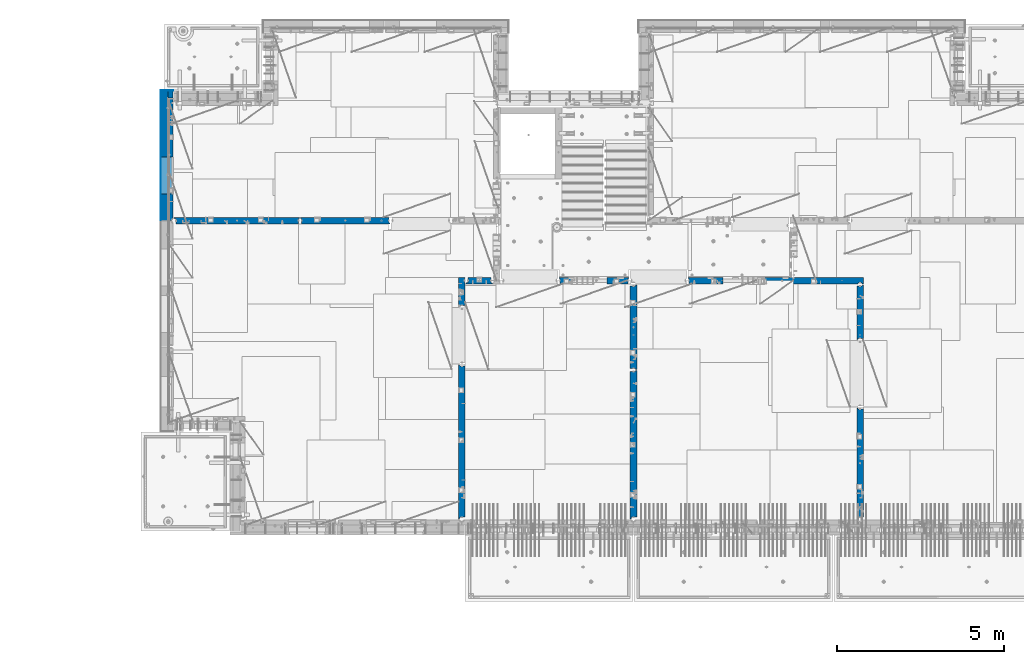
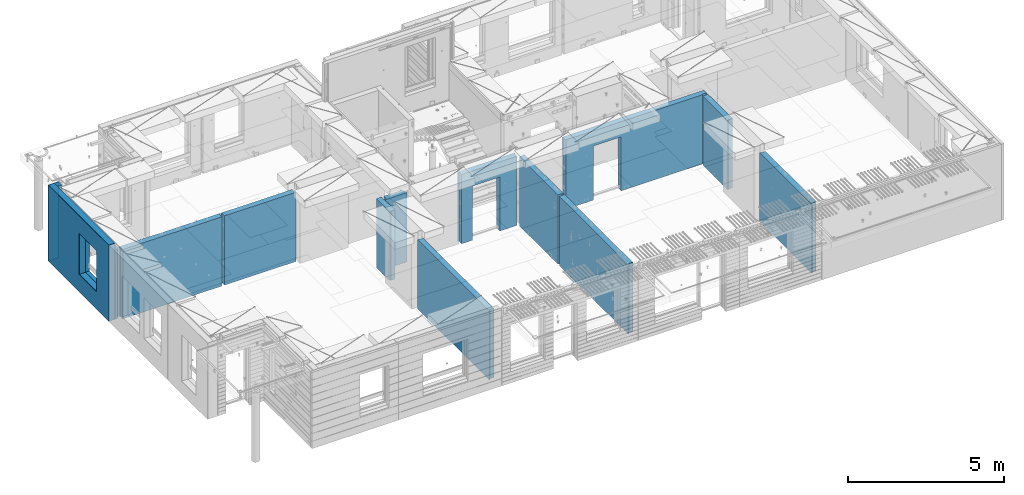
# One storey, part 234 of 349: 16 walls, 12 elements without a shape of their own.
"""IFC2X3 building model written with IfcOpenShell, lengths in millimetres."""

from ifc_helpers import new_model, si_unit, frame, origin_with_axes, place, context, subcontext, project, spatial, faceted_brep, material, type_object, element, aggregate, save


model = new_model("IFC2X3")

# Units and contexts
model_context = context("Model", 3, precision=1e-05, world=origin_with_axes())
body_context = subcontext(model_context, "Body", "Model", "MODEL_VIEW")
ifc_project = project(units=[si_unit("LENGTHUNIT", "METRE", prefix="MILLI"), si_unit("AREAUNIT", "SQUARE_METRE"), si_unit("VOLUMEUNIT", "CUBIC_METRE"), si_unit("MASSUNIT", "GRAM", prefix="KILO"), si_unit("TIMEUNIT", "SECOND"), si_unit("PLANEANGLEUNIT", "RADIAN"), si_unit("SOLIDANGLEUNIT", "STERADIAN"), si_unit("THERMODYNAMICTEMPERATUREUNIT", "DEGREE_CELSIUS"), si_unit("LUMINOUSINTENSITYUNIT", "LUMEN")], contexts=[model_context])

# Site, building, storey
site_placement = place(None, origin_with_axes())
site = spatial("IfcSite", under=ifc_project, at=site_placement, CompositionType="ELEMENT")
building_placement = place(site_placement, origin_with_axes())
building = spatial("IfcBuilding", under=site, at=building_placement, CompositionType="ELEMENT")
storey_placement = place(building_placement, origin_with_axes())
storey = spatial("IfcBuildingStorey", under=building, at=storey_placement, Name="4", CompositionType="ELEMENT", Elevation=0.0)

# Assembly, wall
assembly_1_placement = place(storey_placement, origin_with_axes())
assembly_1 = element("IfcElementAssembly", 1, at=assembly_1_placement, inside=storey, AssemblyPlace="NOTDEFINED", PredefinedType="REINFORCEMENT_UNIT")
ifc_material_1 = material(Name="CONCRETE/C25/30")
wall_type_1 = type_object("IfcWallType", PredefinedType="NOTDEFINED")
wall_1_placement = place(assembly_1_placement, frame((28610.0, 13387.9996249472, 92112.5), z_axis=(0.0, 0.0, 1.0), x_axis=(0.0, 1.0, 0.0)))
wall_1 = element("IfcWall", 2, at=wall_1_placement, type_object=wall_type_1, material=ifc_material_1, context=body_context, shape_type="Brep", body=[
    faceted_brep([(30.9999999999982, 70.0000000000073, 1357.5), (30.9999999999982, 70.0000000000073, -1357.5), (60.9999999999982, 57.0000000000036, -1357.5), (60.9999999999982, 57.0000000000036, 1357.5), (60.9999999999982, -100.0, 1357.5), (60.9999999999982, -100.0, -1357.5), (30.9999999999982, 100.0, -1357.5), (30.9999999999982, 100.0, 1357.5), (1631.00037505278, 100.0, 1357.5), (1631.00037505278, 100.0, -1357.5), (1631.00037505278, -56.9999999999964, 1357.5), (1631.00037505278, -56.9999999999964, -1357.5), (1661.00037505278, -70.0, 1357.5), (1661.00037505278, -70.0, -1357.5), (1661.00037505278, -100.0, 1357.5), (1661.00037505278, -100.0, -1357.5)], [[[0, 1, 2, 3]], [[4, 3, 2, 5]], [[6, 7, 8, 9]], [[10, 11, 9, 8]], [[12, 13, 11, 10]], [[14, 15, 13, 12]], [[15, 14, 4, 5]], [[1, 6, 9, 11, 13, 15, 5, 2]], [[7, 6, 1, 0]], [[14, 12, 10, 8, 7, 0, 3, 4]]]),
])
aggregate(assembly_1, [wall_1])

assembly_2_placement = place(storey_placement, origin_with_axes())
assembly_2 = element("IfcElementAssembly", 3, at=assembly_2_placement, inside=storey, AssemblyPlace="NOTDEFINED", PredefinedType="REINFORCEMENT_UNIT")
wall_2_placement = place(assembly_2_placement, frame((28610.0, 8000.0, 92112.5), z_axis=(0.0, 0.0, 1.0), x_axis=(0.0, 1.0, 0.0)))
wall_2 = element("IfcWall", 4, at=wall_2_placement, type_object=wall_type_1, material=ifc_material_1, context=body_context, shape_type="Brep", body=[
    faceted_brep([(30.0000000000009, 70.0, 1357.5), (30.0, 70.0, -1357.5), (80.0, 57.0, -1357.5), (79.99999955967, 57.0000001052285, 1357.5), (79.9999996695051, -100.0, 1357.5), (80.0, -100.0, -1357.5), (30.0, 100.0, -1357.5), (30.0000000000009, 100.0, 1357.5), (3360.0, 100.0, 1357.5), (3360.0, 100.0, -1357.5), (3360.0, 70.0000000000073, 1357.5), (3360.0, 70.0000000000073, -1357.5), (3330.0, 57.0000000000036, 1357.5), (3330.0, 57.0000000000036, -1357.5), (3330.0, -100.0, 1357.5), (3330.0, -100.0, -1357.5)], [[[0, 1, 2, 3]], [[4, 3, 2, 5]], [[6, 7, 8, 9]], [[9, 8, 10, 11]], [[12, 13, 11, 10]], [[14, 15, 13, 12]], [[15, 14, 4, 5]], [[1, 6, 9, 11, 13, 15, 5, 2]], [[7, 6, 1, 0]], [[14, 12, 10, 8, 7, 0, 3, 4]]]),
])
aggregate(assembly_2, [wall_2])

assembly_3_placement = place(storey_placement, origin_with_axes())
assembly_3 = element("IfcElementAssembly", 5, at=assembly_3_placement, inside=storey, AssemblyPlace="NOTDEFINED", PredefinedType="REINFORCEMENT_UNIT")
wall_3_placement = place(assembly_3_placement, frame((23410.0002919986, 15180.0, 92112.5), z_axis=(0.0, 0.0, 1.0), x_axis=(1.0, 0.0, 0.0)))
wall_3 = element("IfcWall", 6, at=wall_3_placement, type_object=wall_type_1, material=ifc_material_1, context=body_context, shape_type="Brep", body=[
    faceted_brep([(3134.99885559082, 100.0, 762.5), (3147.99885559082, 80.0, 762.5), (3251.99885559082, 80.0, 762.5), (3264.99885559082, 100.0, 762.5), (3147.99885559082, 80.0, 1357.5), (3134.99885559082, 100.0, 1357.5), (3251.99885559082, 80.0, 1357.5), (3264.99885559082, 100.0, 1357.5), (5299.99970800144, -100.0, -1357.5), (5299.99970800144, -100.0, 1357.5), (5264.99970800144, -100.0, 1357.5), (5264.99970800144, -100.0, -1357.5), (5251.99970800144, -70.0, 1357.5), (5251.99970800144, -70.0, -1357.5), (5147.99970800144, -70.0, 1357.5), (5147.99970800144, -70.0, -1357.5), (5134.99970800144, -100.0, 1357.5), (5134.99970800144, -100.0, -1357.5), (59.9988535092562, -100.0, 1357.5), (59.9988535092562, -100.0, -1357.5), (1090.00039464695, -100.0, -1357.5), (1090.00039464695, -100.0, 762.5), (2110.00039464695, -100.0, 762.5), (2110.00039464695, -100.0, -1357.5), (59.9988535092562, 57.0, 1357.5), (59.9988535092562, 57.0, -1357.5), (29.9988535092562, 70.0000000000018, 1357.5), (29.9988535092562, 70.0000000000018, -1357.5), (29.9988535092562, 100.0, 1357.5), (29.9988535092562, 100.0, -1357.5), (1090.00039464695, 100.0, -1357.5), (1090.00039464695, 100.0, 762.5), (2110.00039464695, 100.0, 762.5), (2110.00039464695, 100.0, -1357.5), (5299.99970800144, 100.0, -1357.5), (5299.99970800144, 100.0, 1357.5)], [[[0, 1, 2, 3]], [[4, 1, 0, 5]], [[6, 2, 1, 4]], [[7, 3, 2, 6]], [[8, 9, 10, 11]], [[10, 12, 13, 11]], [[14, 15, 13, 12]], [[16, 17, 15, 14]], [[17, 16, 18, 19, 20, 21, 22, 23]], [[24, 25, 19, 18]], [[26, 27, 25, 24]], [[28, 29, 27, 26]], [[19, 25, 27, 29, 30, 20]], [[31, 21, 20, 30]], [[32, 22, 21, 31]], [[33, 23, 22, 32]], [[34, 8, 11, 13, 15, 17, 23, 33]], [[9, 8, 34, 35]], [[4, 5, 28, 26, 24, 18, 16, 14, 12, 10, 9, 35, 7, 6]], [[35, 34, 33, 32, 31, 30, 29, 28, 5, 0, 3, 7]]]),
])
aggregate(assembly_3, [wall_3])

assembly_4_placement = place(storey_placement, origin_with_axes())
assembly_4 = element("IfcElementAssembly", 7, at=assembly_4_placement, inside=storey, AssemblyPlace="NOTDEFINED", PredefinedType="REINFORCEMENT_UNIT")
wall_4_placement = place(assembly_4_placement, frame((21810.0, 12500.0, 92112.5), z_axis=(0.0, 0.0, 1.0), x_axis=(0.0, 1.0, 0.0)))
wall_4 = element("IfcWall", 8, at=wall_4_placement, type_object=wall_type_1, material=ifc_material_1, context=body_context, shape_type="Brep", body=[
    faceted_brep([(2519.9998239177, -57.0, 1357.5), (2519.9998239177, -57.0, -1357.5), (2519.9998239177, 100.0, -1357.5), (2519.9998239177, 100.0, 1357.5), (2549.9998239177, -70.0, 1357.5), (2549.9998239177, -70.0, -1357.5), (45.0, 100.0, 1357.5), (45.0, 100.0, -1357.5), (45.0, -57.0, -1357.5), (45.0, -57.0, 1357.5), (15.0, -70.0, 1357.5), (15.0, -70.0000000000036, -1357.5), (15.0, -100.0, -1357.5), (15.0, -100.0, 1357.5), (2549.9998239177, -100.0, -1357.5), (2549.9998239177, -100.0, 1357.5)], [[[0, 1, 2, 3]], [[4, 5, 1, 0]], [[6, 7, 8, 9]], [[10, 9, 8, 11]], [[12, 13, 10, 11]], [[13, 12, 14, 15]], [[3, 6, 9, 10, 13, 15, 4, 0]], [[7, 6, 3, 2]], [[14, 12, 11, 8, 7, 2, 1, 5]], [[15, 14, 5, 4]]]),
])
aggregate(assembly_4, [wall_4])

assembly_5_placement = place(storey_placement, origin_with_axes())
assembly_5 = element("IfcElementAssembly", 9, at=assembly_5_placement, inside=storey, AssemblyPlace="NOTDEFINED", PredefinedType="REINFORCEMENT_UNIT")
wall_5_placement = place(assembly_5_placement, frame((21810.0, 8000.0, 92112.5), z_axis=(0.0, 0.0, 1.0), x_axis=(0.0, 1.0, 0.0)))
wall_5 = element("IfcWall", 10, at=wall_5_placement, type_object=wall_type_1, material=ifc_material_1, context=body_context, shape_type="Brep", body=[
    faceted_brep([(30.0000000000009, 70.0, 1357.5), (30.0, 70.0, -1357.5), (80.0, 57.0, -1357.5), (79.99999955967, 57.0000001052285, 1357.5), (79.9999996695051, -100.0, 1357.5), (80.0, -100.0, -1357.5), (30.0, 100.0, -1357.5), (30.0000000000009, 100.0, 1357.5), (4455.0, 100.0, 1357.5), (4455.0, 100.0, -1357.5), (4455.0, -57.0, 1357.5), (4455.0, -57.0, -1357.5), (4485.0, -70.0000000000036, 1357.5), (4485.0, -70.0000000000036, -1357.5), (4485.0, -100.0, 1357.5), (4485.0, -100.0, -1357.5)], [[[0, 1, 2, 3]], [[4, 3, 2, 5]], [[6, 7, 8, 9]], [[10, 11, 9, 8]], [[12, 13, 11, 10]], [[14, 15, 13, 12]], [[15, 14, 4, 5]], [[1, 6, 9, 11, 13, 15, 5, 2]], [[7, 6, 1, 0]], [[14, 12, 10, 8, 7, 0, 3, 4]]]),
])
aggregate(assembly_5, [wall_5])

assembly_6_placement = place(storey_placement, origin_with_axes())
assembly_6 = element("IfcElementAssembly", 11, at=assembly_6_placement, inside=storey, AssemblyPlace="NOTDEFINED", PredefinedType="REINFORCEMENT_UNIT")
wall_6_placement = place(assembly_6_placement, frame((19569.9991455076, 15180.0000000001, 92112.5), z_axis=(0.0, 0.0, 1.0), x_axis=(1.0, 0.0, 0.0)))
wall_6 = element("IfcWall", 12, at=wall_6_placement, type_object=wall_type_1, material=ifc_material_1, context=body_context, shape_type="Brep", body=[
    faceted_brep([(30.0000000001819, 56.9999999999745, 1357.5), (30.0000000001819, 56.9999999999745, -1357.5), (30.0000000001819, -100.0, -1357.5), (30.0000000001819, -100.0, 1357.5), (0.0, 69.9999999999745, 1357.5), (0.0, 69.9999999999745, -1357.5), (1450.00154113788, 100.0, -1357.5), (1450.00154113788, -100.0, -1357.5), (1450.00154113788, -100.0, 762.5), (1450.00154113788, 100.0, 762.5), (430.001541137881, 100.0, 762.5), (430.001541137881, -100.0, 762.5), (430.001541137881, -100.0, -1357.5), (430.001541137881, 100.0, -1357.5), (0.0, 100.0, -1357.5), (0.0, 100.0, 1357.5), (2110.00085449221, 100.0, 1357.5), (2110.00085449221, 100.0, -1357.5), (2110.00085449272, 70.0000000037435, 1357.5), (2110.00085449221, 70.0000000037435, -1357.5), (2080.00085191853, -100.0, -1357.5), (2080.00085558004, 57.0000004585763, -1357.5), (2080.00085558004, 57.0000004585763, 1357.5), (2080.00085191853, -100.0, 1357.5)], [[[0, 1, 2, 3]], [[4, 5, 1, 0]], [[6, 7, 8, 9]], [[10, 11, 12, 13]], [[9, 8, 11, 10]], [[13, 14, 15, 16, 17, 6, 9, 10]], [[17, 16, 18, 19]], [[20, 7, 6, 17, 19, 21]], [[18, 22, 21, 19]], [[23, 20, 21, 22]], [[12, 11, 8, 7, 20, 23, 3, 2]], [[14, 13, 12, 2, 1, 5]], [[15, 14, 5, 4]], [[23, 22, 18, 16, 15, 4, 0, 3]]]),
])
aggregate(assembly_6, [wall_6])

assembly_7_placement = place(storey_placement, origin_with_axes())
assembly_7 = element("IfcElementAssembly", 13, at=assembly_7_placement, inside=storey, AssemblyPlace="NOTDEFINED", PredefinedType="REINFORCEMENT_UNIT")
wall_7_placement = place(assembly_7_placement, frame((16660.0, 8000.0, 92112.5), z_axis=(0.0, 0.0, 1.0), x_axis=(0.0, 1.0, 0.0)))
wall_7 = element("IfcWall", 14, at=wall_7_placement, type_object=wall_type_1, material=ifc_material_1, context=body_context, shape_type="Brep", body=[
    faceted_brep([(30.0000000000009, 70.0, 1357.5), (30.0, 70.0, -1357.5), (80.0, 57.0, -1357.5), (79.99999955967, 57.0000001052285, 1357.5), (79.9999996695051, -100.0, 1357.5), (80.0, -100.0, -1357.5), (30.0, 100.0, -1357.5), (30.0000000000009, 100.0, 1357.5), (4644.99239711402, 100.0, 1357.5), (4644.99239711402, 100.0, -1357.5), (4644.99653549905, 70.0145277302508, 1357.5), (4644.99653549905, 70.0145277302508, -1357.5), (4614.97833252975, 57.001718635147, 1357.5), (4614.97833252975, 57.001718635147, -1357.5), (4615.00000080787, -100.0, 1357.5), (4615.00000080787, -100.0, -1357.5)], [[[0, 1, 2, 3]], [[4, 3, 2, 5]], [[6, 7, 8, 9]], [[9, 8, 10, 11]], [[12, 13, 11, 10]], [[14, 15, 13, 12]], [[15, 14, 4, 5]], [[1, 6, 9, 11, 13, 15, 5, 2]], [[7, 6, 1, 0]], [[14, 12, 10, 8, 7, 0, 3, 4]]]),
])
aggregate(assembly_7, [wall_7])

assembly_8_placement = place(storey_placement, origin_with_axes())
assembly_8 = element("IfcElementAssembly", 15, at=assembly_8_placement, inside=storey, AssemblyPlace="NOTDEFINED", PredefinedType="REINFORCEMENT_UNIT")
wall_8_placement = place(assembly_8_placement, frame((16660.0, 14375.0001284873, 92112.5), z_axis=(0.0, 0.0, 1.0), x_axis=(0.0, 1.0, 0.0)))
wall_8 = element("IfcWall", 16, at=wall_8_placement, type_object=wall_type_1, material=ifc_material_1, context=body_context, shape_type="Brep", body=[
    faceted_brep([(59.9783637637502, 57.008280238686, -607.5), (29.9765698802239, 70.004139724977, -607.5), (29.972430061518, 100.0, -607.5), (84.972430061518, 100.0, -607.5), (84.972430061518, 50.0, -607.5), (59.9793309975266, 50.0, -607.5), (84.972430061518, 50.0, -1357.5), (84.972430061518, 100.0, -1357.5), (59.9793309975285, 50.0, -1357.5), (739.999871512746, -100.0, 1357.5), (752.999871512742, -80.0, 1357.5), (856.999871512742, -80.0, 1357.5), (869.99987151274, -100.0, 1357.5), (904.999871512742, -100.0, 1357.5), (904.999871512742, 100.0, 1357.5), (29.972430061518, 100.0, 1357.5), (29.9765698802239, 70.004139724977, 1357.5), (59.9783637637502, 57.008280238686, 1357.5), (60.0000329474624, -100.0, 1357.5), (739.999871512746, -100.0, -1357.5), (60.0000329474624, -100.0, -1357.5), (752.999871512742, -80.0, -1357.5), (856.999871512742, -80.0, -1357.5), (869.99987151274, -100.0, -1357.5), (904.999871512742, -100.0, -1357.5), (904.999871512742, 100.0, -1357.5)], [[[0, 1, 2, 3, 4, 5]], [[6, 4, 3, 7]], [[8, 5, 4, 6]], [[9, 10, 11, 12, 13, 14, 15, 16, 17, 18]], [[19, 9, 18, 20]], [[9, 19, 21, 10]], [[10, 21, 22, 11]], [[12, 11, 22, 23]], [[24, 13, 12, 23]], [[13, 24, 25, 14]], [[15, 14, 25, 7, 3, 2]], [[16, 15, 2, 1]], [[17, 16, 1, 0]], [[20, 18, 17, 0, 5, 8]], [[25, 24, 23, 22, 21, 19, 20, 8, 6, 7]]]),
])
aggregate(assembly_8, [wall_8])

assembly_9_placement = place(storey_placement, origin_with_axes())
assembly_9 = element("IfcElementAssembly", 17, at=assembly_9_placement, inside=storey, AssemblyPlace="NOTDEFINED", PredefinedType="REINFORCEMENT_UNIT")
wall_9_placement = place(assembly_9_placement, frame((16790.0, 15180.0, 92112.5), z_axis=(0.0, 0.0, 1.0), x_axis=(1.0, 0.0, 0.0)))
wall_9 = element("IfcWall", 18, at=wall_9_placement, type_object=wall_type_1, material=ifc_material_1, context=body_context, shape_type="Brep", body=[
    faceted_brep([(740.0, 100.0, 1357.5), (740.0, -57.0, 1357.5), (740.0, -57.0, -1357.5), (740.0, 100.0, -1357.5), (790.0, -70.0, 1357.5), (790.0, -69.9999999999982, -1357.5), (50.0, 100.0, 1357.5), (50.0, 100.0, -1357.5), (50.0, -48.3299999999999, -1357.5), (50.0, -48.3299999999999, 1357.5), (0.0, -69.996666666666, -1357.5), (0.0, -69.996666666666, 1357.5), (0.0, -100.0, -1357.5), (0.0, -100.0, 1357.5), (790.0, -100.0, -1357.5), (790.0, -100.0, 1357.5)], [[[0, 1, 2, 3]], [[4, 5, 2, 1]], [[6, 7, 8, 9]], [[9, 8, 10, 11]], [[12, 13, 11, 10]], [[13, 12, 14, 15]], [[1, 0, 6, 9, 11, 13, 15, 4]], [[7, 6, 0, 3]], [[14, 12, 10, 8, 7, 3, 2, 5]], [[15, 14, 5, 4]]]),
])
aggregate(assembly_9, [wall_9])

assembly_10_placement = place(storey_placement, origin_with_axes())
assembly_10 = element("IfcElementAssembly", 19, at=assembly_10_placement, inside=storey, AssemblyPlace="NOTDEFINED", PredefinedType="REINFORCEMENT_UNIT")
wall_10_placement = place(assembly_10_placement, frame((11795.0, 16980.0, 92112.5), z_axis=(0.0, 0.0, 1.0), x_axis=(1.0, 0.0, 0.0)))
wall_10 = element("IfcWall", 20, at=wall_10_placement, type_object=wall_type_1, material=ifc_material_1, context=body_context, shape_type="Brep", body=[
    faceted_brep([(2680.0, 100.0, 1357.5), (2680.0, -57.0, 1357.5), (2680.0, -57.0, -1357.50000000001), (2680.0, 100.0, -1357.5), (2705.0, -67.8333333333321, 1357.5), (2705.0, -67.8333333333321, -1357.5), (25.0, 100.0, 1357.5), (25.0, 100.0, -1357.5), (25.0, 70.0000000000036, -1357.5), (25.0, 70.0000000000036, 1357.5), (55.0, 57.0, -1357.5), (55.0, 57.0, 1357.5), (55.0, -100.0, -1357.5), (55.0, -100.0, 1357.5), (2705.0, -100.0, -1357.5), (2705.0, -100.0, 1357.5)], [[[0, 1, 2, 3]], [[4, 5, 2, 1]], [[6, 7, 8, 9]], [[9, 8, 10, 11]], [[11, 10, 12, 13]], [[14, 15, 13, 12]], [[0, 6, 9, 11, 13, 15, 4, 1]], [[7, 6, 0, 3]], [[14, 12, 10, 8, 7, 3, 2, 5]], [[15, 14, 5, 4]]]),
])
aggregate(assembly_10, [wall_10])

assembly_11_placement = place(storey_placement, origin_with_axes())
assembly_11 = element("IfcElementAssembly", 21, at=assembly_11_placement, inside=storey, AssemblyPlace="NOTDEFINED", PredefinedType="REINFORCEMENT_UNIT")
wall_11_placement = place(assembly_11_placement, frame((8000.0, 16980.0, 92112.5), z_axis=(0.0, 0.0, 1.0), x_axis=(1.0, 0.0, 0.0)))
wall_11 = element("IfcWall", 22, at=wall_11_placement, type_object=wall_type_1, material=ifc_material_1, context=body_context, shape_type="Brep", body=[
    faceted_brep([(80.0, 52.0, 1357.5), (80.0, 52.0, -1357.5), (80.0, -100.0, -1357.5), (79.9999996695051, -100.0, 1357.5), (30.0000022791291, 65.0, 1357.5), (30.0000022791291, 65.0, -1357.5), (30.0, 100.0, -1357.5), (30.0000000000009, 100.0, 1357.5), (3790.0, 100.0, 1357.5), (3790.0, 100.0, -1357.5), (3790.0, 70.0000000000036, 1357.5), (3790.0, 70.0000000000036, -1357.5), (3760.0, 57.0, 1357.5), (3760.0, 57.0, -1357.5), (3760.0, -100.0, 1357.5), (3760.0, -100.0, -1357.5)], [[[0, 1, 2, 3]], [[4, 5, 1, 0]], [[6, 7, 8, 9]], [[9, 8, 10, 11]], [[10, 12, 13, 11]], [[14, 15, 13, 12]], [[15, 14, 3, 2]], [[6, 9, 11, 13, 15, 2, 1, 5]], [[7, 6, 5, 4]], [[14, 12, 10, 8, 7, 4, 0, 3]]]),
])
aggregate(assembly_11, [wall_11])

# Assembly, walls
assembly_12_placement = place(storey_placement, origin_with_axes())
assembly_12 = element("IfcElementAssembly", 23, at=assembly_12_placement, inside=storey, AssemblyPlace="NOTDEFINED", PredefinedType="REINFORCEMENT_UNIT")
ifc_material_2 = material()
wall_type_2 = type_object("IfcWallType", PredefinedType="NOTDEFINED")
wall_12_placement = place(assembly_12_placement, frame((7850.0, 20764.9951872276, 92247.5), z_axis=(0.0, 0.0, 1.0), x_axis=(1.0, 0.0, 0.0)))
wall_12 = element("IfcWall", 24, at=wall_12_placement, type_object=wall_type_2, material=ifc_material_2, context=body_context, shape_type="Brep", body=[
    faceted_brep([(0.0, 110.0, -1492.5), (0.0, 110.0, 1492.5), (150.0, 110.0, 1492.5), (150.0, 110.0, -1492.5), (0.0, -110.0, 1492.5), (150.0, -110.0, 1492.5), (0.0, -110.0, -1492.5), (150.0, -110.0, -1492.5)], [[[0, 1, 2, 3]], [[1, 4, 5, 2]], [[4, 6, 7, 5]], [[6, 0, 3, 7]], [[5, 7, 3, 2]], [[6, 4, 1, 0]]]),
])
wall_13_placement = place(assembly_12_placement, frame((7740.0, 16980.0, 92247.5), z_axis=(0.0, 0.0, 1.0), x_axis=(0.0, 1.0, 0.0)))
wall_13 = element("IfcWall", 25, at=wall_13_placement, type_object=wall_type_2, material=ifc_material_2, context=body_context, shape_type="Brep", body=[
    faceted_brep([(5.0, -110.0, 1492.5), (5.0, -110.0, -1492.5), (3894.99518722756, -110.0, -1492.5), (3894.99518722756, -110.0, 1492.5), (795.000410774857, -110.0, -802.5), (795.000410774857, -110.0, 807.5), (1905.00041077486, -110.0, 807.5), (1905.00041077486, -110.0, -802.5), (5.0, 110.0, 1492.5), (3894.99518722756, 110.0, 1492.5), (5.0, 110.0, -1492.5), (3894.99518722756, 110.0, -1492.5), (795.000410774857, 110.0, -802.5), (1905.00041077486, 110.0, -802.5), (1905.00041077486, 110.0, 807.5), (795.000410774857, 110.0, 807.5)], [[[0, 1, 2, 3], [4, 5, 6, 7]], [[8, 0, 3, 9]], [[1, 0, 8, 10]], [[1, 10, 11, 2]], [[3, 2, 11, 9]], [[10, 8, 9, 11], [12, 13, 14, 15]], [[6, 14, 13, 7]], [[5, 15, 14, 6]], [[4, 12, 15, 5]], [[7, 13, 12, 4]]]),
])
wall_type_3 = type_object("IfcWallType", PredefinedType="NOTDEFINED")
wall_14_placement = place(assembly_12_placement, frame((7925.0, 16980.0, 92112.5), z_axis=(0.0, 0.0, 1.0), x_axis=(0.0, 1.0, 0.0)))
wall_14 = element("IfcWall", 26, at=wall_14_placement, type_object=wall_type_3, material=ifc_material_1, context=body_context, shape_type="Brep", body=[
    faceted_brep([(1905.00041077486, -75.0000002638189, -667.5), (1905.00041077486, 75.0, -667.5), (795.000410774857, 75.0, -667.5), (795.000410774857, -75.0000006142109, -667.5), (795.000410774857, 75.0, 942.5), (795.000410774857, -75.0000013255412, 942.5), (1905.00041077486, 75.0, 942.5), (1905.00041077486, -75.0000009751493, 942.5), (3674.99518722756, -75.0, -1357.5), (3674.99518722756, -75.0, 1357.5), (3564.99519001209, -75.0000022791282, 1357.5), (3564.99519001209, -75.0, -1357.5), (3674.99518722756, 75.0, 1357.5), (5.0, 75.0, 1357.5), (5.0, -15.0000022791291, 1357.5), (65.0, -75.0, 1357.5), (3484.99518722756, -75.0000001199542, 1357.5), (3497.99518763813, -54.9999993903657, 1357.5), (3551.99518754267, -54.9999994175314, 1357.5), (5.0, 75.0, -1357.5), (5.0, -15.0000022791291, -1357.5), (65.0, -75.0, -1357.5), (3484.99518722756, -75.0, -1357.5), (3497.99518763813, -54.9999993903657, -1357.5), (3551.99518754267, -54.9999994175314, -1357.5), (3674.99518722756, 75.0, -1357.5)], [[[0, 1, 2, 3]], [[3, 2, 4, 5]], [[5, 4, 6, 7]], [[7, 6, 1, 0]], [[8, 9, 10, 11]], [[9, 12, 13, 14, 15, 16, 17, 18, 10]], [[13, 19, 20, 14]], [[15, 14, 20, 21]], [[15, 21, 22, 16], [3, 5, 7, 0]], [[16, 22, 23, 17]], [[17, 23, 24, 18]], [[10, 18, 24, 11]], [[23, 22, 21, 20, 19, 25, 8, 11, 24]], [[9, 8, 25, 12]], [[19, 13, 12, 25], [2, 1, 6, 4]]]),
])
ifc_material_3 = material(Name="CONCRETE/C30/37")
wall_type_4 = type_object("IfcWallType", PredefinedType="NOTDEFINED")
wall_15_placement = place(assembly_12_placement, frame((7630.0, 20879.9952125549, 92247.5), z_axis=(0.0, 0.0, 1.0), x_axis=(1.0, 0.0, 0.0)))
wall_15 = element("IfcWall", 27, at=wall_15_placement, type_object=wall_type_4, material=ifc_material_3, context=body_context, shape_type="Brep", body=[
    faceted_brep([(0.0, 5.0, -1492.5), (0.0, 5.0, 1492.5), (370.0, 5.0, 1492.5), (370.0, 5.0, -1492.5), (0.0, -5.0, 1492.5), (370.0, -5.0, 1492.5), (0.0, -5.0, -1492.5), (370.0, -5.0, -1492.5)], [[[0, 1, 2, 3]], [[1, 4, 5, 2]], [[4, 6, 7, 5]], [[6, 0, 3, 7]], [[5, 7, 3, 2]], [[6, 4, 1, 0]]]),
])
wall_16_placement = place(assembly_12_placement, frame((7625.0, 16980.0, 92247.5), z_axis=(0.0, 0.0, 1.0), x_axis=(0.0, 1.0, 0.0)))
wall_16 = element("IfcWall", 28, at=wall_16_placement, type_object=wall_type_4, material=ifc_material_3, context=body_context, shape_type="Brep", body=[
    faceted_brep([(5.0, -5.0, 1492.5), (5.0, -5.0, -1492.5), (3904.99518722756, -5.0, -1492.5), (3904.99518722756, -5.0, 1492.5), (795.000410774981, -5.0, -802.5), (795.000410774981, -5.0, 807.5), (1905.00041077498, -5.0, 807.5), (1905.00041077498, -5.0, -802.5), (5.0, 5.0, 1492.5), (3904.99518722756, 5.0, 1492.5), (5.0, 5.0, -1492.5), (3904.99518722756, 5.0, -1492.5), (795.000410774981, 5.0, -802.5), (1905.00041077498, 5.0, -802.5), (1905.00041077498, 5.0, 807.5), (795.000410774981, 5.0, 807.5)], [[[0, 1, 2, 3], [4, 5, 6, 7]], [[8, 0, 3, 9]], [[1, 0, 8, 10]], [[1, 10, 11, 2]], [[3, 2, 11, 9]], [[10, 8, 9, 11], [12, 13, 14, 15]], [[6, 14, 13, 7]], [[5, 15, 14, 6]], [[4, 12, 15, 5]], [[7, 13, 12, 4]]]),
])
aggregate(assembly_12, [wall_12, wall_15, wall_13, wall_16, wall_14])

save(model, "model.ifc")
